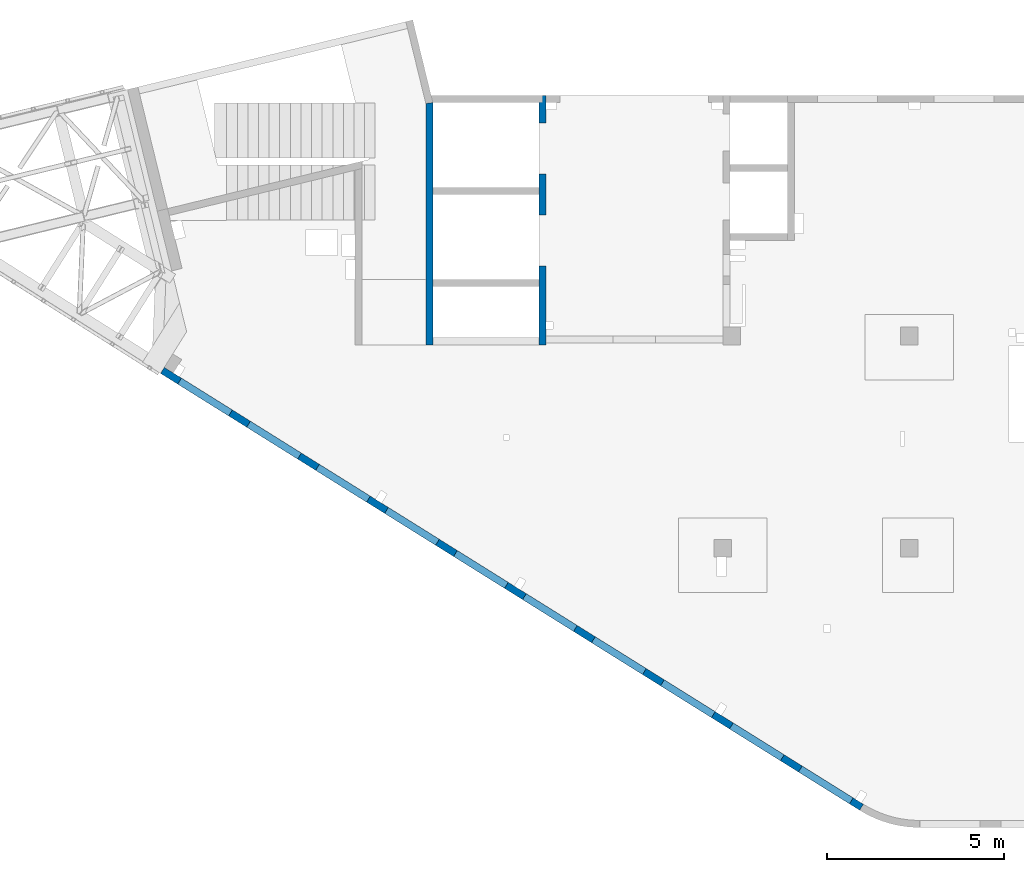
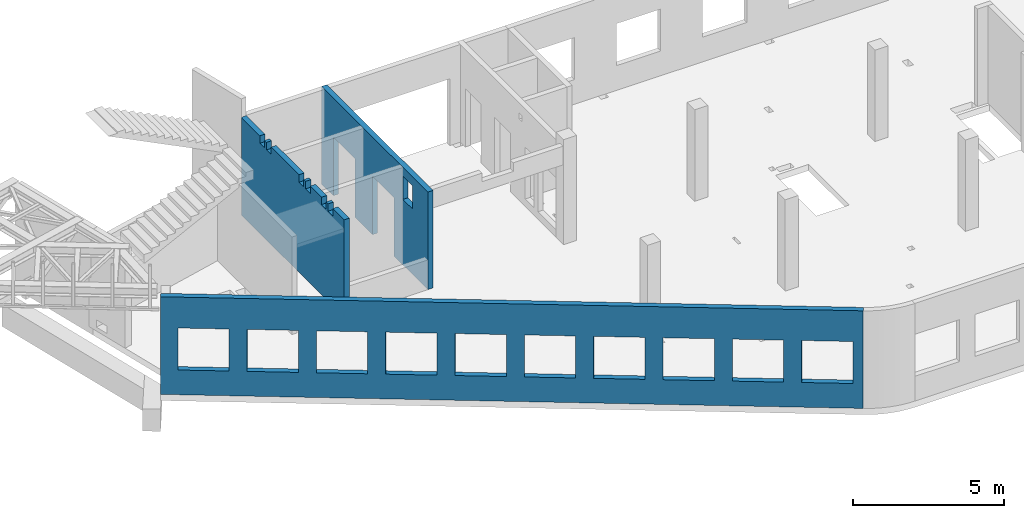
# One storey, part 64 of 67: 3 walls, 19 openings.
"""IFC4 building model written with IfcOpenShell, lengths in millimetres."""

from ifc_helpers import new_model, entity, si_unit, converted_unit, derived_unit, direction, frame, origin, place, context, subcontext, project, spatial, indexed_curve, outline, extrude, polygons, material, type_object, element, save


model = new_model("IFC4")

# Units and contexts
model_context = context("Model", 3, precision=0.01, world=origin(), true_north=direction((6.12303176911189e-17, 1.0)))
plan_context = context("Plan", 3, precision=0.01, world=origin(), true_north=direction((6.12303176911189e-17, 1.0)))
body_context = subcontext(model_context, "Body", "Model", "MODEL_VIEW")
ifc_project = project(units=[si_unit("LENGTHUNIT", "METRE", prefix="MILLI"), si_unit("AREAUNIT", "SQUARE_METRE"), si_unit("VOLUMEUNIT", "CUBIC_METRE"), converted_unit("PLANEANGLEUNIT", "DEGREE", entity("IfcRatioMeasure", 0.0174532925199433), si_unit("PLANEANGLEUNIT", "RADIAN"), dimensions=[0, 0, 0, 0, 0, 0, 0]), si_unit("MASSUNIT", "GRAM", prefix="KILO"), derived_unit("MASSDENSITYUNIT", [(si_unit("MASSUNIT", "GRAM", prefix="KILO"), 1), (si_unit("LENGTHUNIT", "METRE"), -3)]), derived_unit("MOMENTOFINERTIAUNIT", [(si_unit("LENGTHUNIT", "METRE"), 4)]), si_unit("TIMEUNIT", "SECOND"), si_unit("FREQUENCYUNIT", "HERTZ"), si_unit("THERMODYNAMICTEMPERATUREUNIT", "DEGREE_CELSIUS"), derived_unit("THERMALTRANSMITTANCEUNIT", [(si_unit("MASSUNIT", "GRAM", prefix="KILO"), 1), (si_unit("THERMODYNAMICTEMPERATUREUNIT", "KELVIN"), -1), (si_unit("TIMEUNIT", "SECOND"), -3)]), derived_unit("VOLUMETRICFLOWRATEUNIT", [(si_unit("LENGTHUNIT", "METRE"), 3), (si_unit("TIMEUNIT", "SECOND"), -1)]), derived_unit("MASSFLOWRATEUNIT", [(si_unit("MASSUNIT", "GRAM", prefix="KILO"), 1), (si_unit("TIMEUNIT", "SECOND"), -1)]), derived_unit("ROTATIONALFREQUENCYUNIT", [(si_unit("TIMEUNIT", "SECOND"), -1)]), si_unit("ELECTRICCURRENTUNIT", "AMPERE"), si_unit("ELECTRICVOLTAGEUNIT", "VOLT"), si_unit("POWERUNIT", "WATT"), si_unit("FORCEUNIT", "NEWTON", prefix="KILO"), si_unit("ILLUMINANCEUNIT", "LUX"), si_unit("LUMINOUSFLUXUNIT", "LUMEN"), si_unit("LUMINOUSINTENSITYUNIT", "CANDELA"), derived_unit("USERDEFINED", [(si_unit("MASSUNIT", "GRAM", prefix="KILO"), -1), (si_unit("LENGTHUNIT", "METRE"), -2), (si_unit("TIMEUNIT", "SECOND"), 3), (si_unit("LUMINOUSFLUXUNIT", "LUMEN"), 1)]), derived_unit("LINEARVELOCITYUNIT", [(si_unit("LENGTHUNIT", "METRE"), 1), (si_unit("TIMEUNIT", "SECOND"), -1)]), si_unit("PRESSUREUNIT", "PASCAL"), derived_unit("USERDEFINED", [(si_unit("LENGTHUNIT", "METRE"), -2), (si_unit("MASSUNIT", "GRAM", prefix="KILO"), 1), (si_unit("TIMEUNIT", "SECOND"), -2)]), derived_unit("LINEARFORCEUNIT", [(si_unit("MASSUNIT", "GRAM", prefix="KILO"), 1), (si_unit("LENGTHUNIT", "METRE"), 1), (si_unit("TIMEUNIT", "SECOND"), -2), (si_unit("LENGTHUNIT", "METRE"), -1)]), derived_unit("PLANARFORCEUNIT", [(si_unit("MASSUNIT", "GRAM", prefix="KILO"), 1), (si_unit("LENGTHUNIT", "METRE"), 1), (si_unit("TIMEUNIT", "SECOND"), -2), (si_unit("LENGTHUNIT", "METRE"), -2)])], contexts=[model_context, plan_context])

# Site, building, storey
site_placement = place(None, origin())
site = spatial("IfcSite", under=ifc_project, at=site_placement, CompositionType="ELEMENT")
building_placement = place(site_placement, origin())
building = spatial("IfcBuilding", under=site, at=building_placement, CompositionType="ELEMENT")
storey_placement = place(building_placement, frame((0.0, 0.0, 19800.0)))
storey = spatial("IfcBuildingStorey", under=building, at=storey_placement, CompositionType="ELEMENT", Elevation=19800.0)

# Wall, openings
ifc_material = material()
wall_type = type_object("IfcWallType", PredefinedType="STANDARD")
wall_1_placement = place(storey_placement, frame((19822.3508929728, 371.159406986363, -150.0), z_axis=(0.0, 0.0, 1.0), x_axis=(-0.848052743777574, 0.529911826412025, 0.0)))
wall_1 = element("IfcWall", 1, at=wall_1_placement, inside=storey, type_object=wall_type, material=ifc_material, PredefinedType="NOTDEFINED", context=body_context, shape_type="Tessellation", body=[
    polygons([(9.13669140345519e-13, -100.0, 0.0), (23011.6394501553, -99.9999999999989, 0.0), (23311.6394501553, -100.000000000001, 0.0), (23311.6394501553, -100.000000000001, 3950.0), (23011.6394501553, -99.9999999999989, 3950.0), (9.13669140345519e-13, -100.0, 3950.0), (21041.6390317217, -100.0, 2700.0), (22741.6390317217, -99.9999999999989, 2700.0), (22741.6390317217, -99.9999999999989, 1000.00000000001), (21041.6390317217, -100.0, 1000.00000000001), (18741.6390317217, -99.9999999999989, 2700.0), (20441.6390317217, -100.000000000001, 2700.0), (20441.6390317217, -100.000000000001, 1000.00000000001), (18741.6390317217, -99.9999999999989, 1000.00000000001), (16441.6390317217, -100.000000000001, 2700.0), (18141.6390317217, -100.000000000001, 2700.0), (18141.6390317217, -100.000000000001, 1000.00000000001), (16441.6390317217, -100.000000000001, 1000.00000000001), (14141.6390317217, -100.0, 2700.0), (15841.6390317217, -100.0, 2700.0), (15841.6390317217, -100.0, 1000.00000000001), (14141.6390317217, -100.0, 1000.00000000001), (11841.6390317217, -99.9999999999989, 2700.0), (13541.6390317217, -100.000000000001, 2700.0), (13541.6390317217, -100.000000000001, 1000.00000000001), (11841.6390317217, -99.9999999999989, 1000.00000000001), (9541.63903172168, -100.000000000001, 2700.0), (11241.6390317217, -100.0, 2700.0), (11241.6390317217, -100.0, 1000.00000000001), (9541.63903172168, -100.000000000001, 1000.00000000001), (7241.63903172167, -99.9999999999995, 2700.0), (8941.63903172167, -99.9999999999995, 2700.0), (8941.63903172167, -99.9999999999995, 1000.00000000001), (7241.63903172167, -99.9999999999995, 1000.00000000001), (4941.63903172166, -99.9999999999989, 2700.0), (6641.63903172166, -99.9999999999989, 2700.0), (6641.63903172166, -99.9999999999989, 1000.00000000001), (4941.63903172166, -99.9999999999989, 1000.00000000001), (2641.63903172165, -100.0, 2700.0), (4341.63903172165, -100.0, 2700.0), (4341.63903172165, -100.0, 1000.00000000001), (2641.63903172165, -100.0, 1000.00000000001), (341.639031721648, -100.000000000002, 2700.0), (2041.63903172165, -100.0, 2700.0), (2041.63903172165, -100.0, 1000.00000000001), (341.639031721648, -100.000000000002, 1000.00000000001), (22741.6390317217, 100.000000000319, 2700.0), (21041.6390317217, 100.000000000321, 2700.0), (21041.6390317217, 100.000000000321, 1000.00000000001), (22741.6390317217, 100.000000000319, 1000.00000000001), (20441.6390317217, 100.000000000319, 2700.0), (18741.6390317217, 100.000000000322, 2700.0), (18741.6390317217, 100.000000000322, 1000.00000000001), (20441.6390317217, 100.000000000319, 1000.00000000001), (18141.6390317217, 100.000000000318, 2700.0), (16441.6390317217, 100.000000000319, 2700.0), (16441.6390317217, 100.000000000319, 1000.00000000001), (18141.6390317217, 100.000000000318, 1000.00000000001), (15841.6390317217, 100.000000000321, 2700.0), (14141.6390317217, 100.000000000322, 2700.0), (14141.6390317217, 100.000000000322, 1000.00000000001), (15841.6390317217, 100.000000000321, 1000.00000000001), (13541.6390317217, 100.000000000319, 2700.0), (11841.6390317217, 100.000000000321, 2700.0), (11841.6390317217, 100.000000000321, 1000.00000000001), (13541.6390317217, 100.000000000319, 1000.00000000001), (11241.6390317217, 100.000000000321, 2700.0), (9541.63903172168, 100.000000000319, 2700.0), (9541.63903172168, 100.000000000319, 1000.00000000001), (11241.6390317217, 100.000000000321, 1000.00000000001), (8941.63903172167, 100.000000000319, 2700.0), (7241.63903172167, 100.000000000321, 2700.0), (7241.63903172167, 100.000000000321, 1000.00000000001), (8941.63903172167, 100.000000000319, 1000.00000000001), (6641.63903172167, 100.000000000322, 2700.0), (4941.63903172166, 100.000000000322, 2700.0), (4941.63903172166, 100.000000000322, 1000.00000000001), (6641.63903172166, 100.000000000322, 1000.00000000001), (4341.63903172166, 100.000000000321, 2700.0), (2641.63903172165, 100.000000000319, 2700.0), (2641.63903172165, 100.000000000319, 1000.00000000001), (4341.63903172166, 100.000000000321, 1000.00000000001), (2041.63903172165, 100.000000000321, 2700.0), (341.639031721653, 100.000000000321, 2700.0), (341.639031721653, 100.00000000032, 1000.00000000001), (2041.63903172165, 100.000000000321, 1000.00000000001), (1.18438592267012e-13, 100.000000000001, 0.0), (1.18438592267012e-13, 100.000000000001, 3950.0), (23311.6394501553, 100.000000000001, 3950.0), (23311.6394501553, 100.000000000001, 0.0)], [[[1, 2, 3, 4, 5, 6], [7, 8, 9, 10], [11, 12, 13, 14], [15, 16, 17, 18], [19, 20, 21, 22], [23, 24, 25, 26], [27, 28, 29, 30], [31, 32, 33, 34], [35, 36, 37, 38], [39, 40, 41, 42], [43, 44, 45, 46]], [[87, 88, 89, 90], [47, 48, 49, 50], [51, 52, 53, 54], [55, 56, 57, 58], [59, 60, 61, 62], [63, 64, 65, 66], [67, 68, 69, 70], [71, 72, 73, 74], [75, 76, 77, 78], [79, 80, 81, 82], [83, 84, 85, 86]], [[3, 2, 1, 87, 90]], [[6, 5, 4, 89, 88]], [[1, 6, 88, 87]], [[4, 3, 90, 89]], [[48, 47, 8, 7]], [[48, 7, 10, 49]], [[49, 10, 9, 50]], [[8, 47, 50, 9]], [[52, 51, 12, 11]], [[52, 11, 14, 53]], [[53, 14, 13, 54]], [[12, 51, 54, 13]], [[56, 55, 16, 15]], [[56, 15, 18, 57]], [[57, 18, 17, 58]], [[16, 55, 58, 17]], [[60, 59, 20, 19]], [[60, 19, 22, 61]], [[61, 22, 21, 62]], [[20, 59, 62, 21]], [[64, 63, 24, 23]], [[64, 23, 26, 65]], [[65, 26, 25, 66]], [[24, 63, 66, 25]], [[68, 67, 28, 27]], [[68, 27, 30, 69]], [[69, 30, 29, 70]], [[28, 67, 70, 29]], [[72, 71, 32, 31]], [[72, 31, 34, 73]], [[73, 34, 33, 74]], [[32, 71, 74, 33]], [[76, 75, 36, 35]], [[76, 35, 38, 77]], [[77, 38, 37, 78]], [[36, 75, 78, 37]], [[80, 79, 40, 39]], [[80, 39, 42, 81]], [[81, 42, 41, 82]], [[40, 79, 82, 41]], [[84, 83, 44, 43]], [[84, 43, 46, 85]], [[85, 46, 45, 86]], [[44, 83, 86, 45]]], closed=True),
])
opening_1_placement = place(wall_1_placement, frame((16613.7173036613, 10818.8609189489, 150.0), z_axis=(0.0, 0.0, 1.0), x_axis=(-0.848052743777574, -0.529911826412026, 0.0)))
element("IfcOpeningElement", 2, at=opening_1_placement, cuts=wall_1, PredefinedType="OPENING", context=body_context, shape_type="SweptSolid", body=[
    extrude(outline(indexed_curve([(-849.999999999993, -850.0), (849.999999999993, -850.0), (849.999999999993, 850.0), (-849.999999999993, 850.0), (-849.999999999993, -850.0)], self_intersect=False)), frame((1310.07752897418, 12056.6031038165, 1700.0), z_axis=(-0.529911826412026, -0.848052743777574, 0.0), x_axis=(0.0, 0.0, -1.0)), (0.0, 0.0, 1.0), 200.000000000959),
])
opening_2_placement = place(wall_1_placement, frame((16613.7173036613, 10818.8609189489, 150.0), z_axis=(0.0, 0.0, 1.0), x_axis=(-0.848052743777574, -0.529911826412026, 0.0)))
element("IfcOpeningElement", 3, at=opening_2_placement, cuts=wall_1, PredefinedType="OPENING", context=body_context, shape_type="SweptSolid", body=[
    extrude(outline(indexed_curve([(-849.999999999993, -850.0), (849.999999999993, -850.0), (849.999999999993, 850.0), (-849.999999999993, 850.0), (-849.999999999993, -850.0)], self_intersect=False)), frame((3260.5988396626, 10837.8059030689, 1700.0), z_axis=(-0.529911826412026, -0.848052743777574, 0.0), x_axis=(0.0, 0.0, -1.0)), (0.0, 0.0, 1.0), 200.000000000962),
])
opening_3_placement = place(wall_1_placement, frame((16613.7173036613, 10818.8609189489, 150.0), z_axis=(0.0, 0.0, 1.0), x_axis=(-0.848052743777574, -0.529911826412026, 0.0)))
element("IfcOpeningElement", 4, at=opening_3_placement, cuts=wall_1, PredefinedType="OPENING", context=body_context, shape_type="SweptSolid", body=[
    extrude(outline(indexed_curve([(-849.999999999993, -849.999999999999), (849.999999999993, -849.999999999999), (849.999999999993, 850.0), (-849.999999999993, 850.0), (-849.999999999993, -849.999999999999)], self_intersect=False)), frame((5211.12015035102, 9619.00870232123, 1700.0), z_axis=(-0.529911826412025, -0.848052743777574, 0.0), x_axis=(0.0, 0.0, -1.0)), (0.0, 0.0, 1.0), 200.000000000962),
])
opening_4_placement = place(wall_1_placement, frame((16613.7173036613, 10818.8609189489, 150.0), z_axis=(0.0, 0.0, 1.0), x_axis=(-0.848052743777574, -0.529911826412026, 0.0)))
element("IfcOpeningElement", 5, at=opening_4_placement, cuts=wall_1, PredefinedType="OPENING", context=body_context, shape_type="SweptSolid", body=[
    extrude(outline(indexed_curve([(-849.999999999993, -849.999999999999), (849.999999999993, -849.999999999999), (849.999999999993, 850.0), (-849.999999999993, 850.0), (-849.999999999993, -849.999999999999)], self_intersect=False)), frame((7161.64146103944, 8400.21150157357, 1700.0), z_axis=(-0.529911826412026, -0.848052743777574, 0.0), x_axis=(0.0, 0.0, -1.0)), (0.0, 0.0, 1.0), 200.000000000962),
])
opening_5_placement = place(wall_1_placement, frame((16613.7173036613, 10818.8609189489, 150.0), z_axis=(0.0, 0.0, 1.0), x_axis=(-0.848052743777574, -0.529911826412026, 0.0)))
element("IfcOpeningElement", 6, at=opening_5_placement, cuts=wall_1, PredefinedType="OPENING", context=body_context, shape_type="SweptSolid", body=[
    extrude(outline(indexed_curve([(-849.999999999993, -849.999999999999), (849.999999999993, -849.999999999999), (849.999999999993, 850.0), (-849.999999999993, 850.0), (-849.999999999993, -849.999999999999)], self_intersect=False)), frame((9112.16277172786, 7181.41430082591, 1700.0), z_axis=(-0.529911826412026, -0.848052743777574, 0.0), x_axis=(0.0, 0.0, -1.0)), (0.0, 0.0, 1.0), 200.000000000959),
])
opening_6_placement = place(wall_1_placement, frame((16613.7173036613, 10818.8609189489, 150.0), z_axis=(0.0, 0.0, 1.0), x_axis=(-0.848052743777574, -0.529911826412026, 0.0)))
element("IfcOpeningElement", 7, at=opening_6_placement, cuts=wall_1, PredefinedType="OPENING", context=body_context, shape_type="SweptSolid", body=[
    extrude(outline(indexed_curve([(-849.999999999993, -850.0), (849.999999999993, -850.0), (849.999999999993, 850.0), (-849.999999999993, 850.0), (-849.999999999993, -850.0)], self_intersect=False)), frame((11062.6840824163, 5962.61710007825, 1700.0), z_axis=(-0.529911826412025, -0.848052743777574, 0.0), x_axis=(0.0, 0.0, -1.0)), (0.0, 0.0, 1.0), 200.000000000964),
])
opening_7_placement = place(wall_1_placement, frame((16613.7173036613, 10818.8609189489, 150.0), z_axis=(0.0, 0.0, 1.0), x_axis=(-0.848052743777574, -0.529911826412026, 0.0)))
element("IfcOpeningElement", 8, at=opening_7_placement, cuts=wall_1, PredefinedType="OPENING", context=body_context, shape_type="SweptSolid", body=[
    extrude(outline(indexed_curve([(-849.999999999993, -850.0), (849.999999999993, -850.0), (849.999999999993, 850.0), (-849.999999999993, 850.0), (-849.999999999993, -850.0)], self_intersect=False)), frame((13013.2053931047, 4743.81989933058, 1700.0), z_axis=(-0.529911826412025, -0.848052743777574, 0.0), x_axis=(0.0, 0.0, -1.0)), (0.0, 0.0, 1.0), 200.000000000962),
])
opening_8_placement = place(wall_1_placement, frame((16613.7173036613, 10818.8609189489, 150.0), z_axis=(0.0, 0.0, 1.0), x_axis=(-0.848052743777574, -0.529911826412026, 0.0)))
element("IfcOpeningElement", 9, at=opening_8_placement, cuts=wall_1, PredefinedType="OPENING", context=body_context, shape_type="SweptSolid", body=[
    extrude(outline(indexed_curve([(-849.999999999993, -850.000000000003), (849.999999999993, -850.000000000003), (849.999999999993, 849.999999999998), (-849.999999999993, 849.999999999998), (-849.999999999993, -850.000000000003)], self_intersect=False)), frame((14963.7267037931, 3525.02269858292, 1700.0), z_axis=(-0.529911826412025, -0.848052743777574, 0.0), x_axis=(0.0, 0.0, -1.0)), (0.0, 0.0, 1.0), 200.000000000962),
])
opening_9_placement = place(wall_1_placement, frame((16613.7173036613, 10818.8609189489, 150.0), z_axis=(0.0, 0.0, 1.0), x_axis=(-0.848052743777574, -0.529911826412026, 0.0)))
element("IfcOpeningElement", 10, at=opening_9_placement, cuts=wall_1, PredefinedType="OPENING", context=body_context, shape_type="SweptSolid", body=[
    extrude(outline(indexed_curve([(-849.999999999993, -849.999999999998), (849.999999999993, -849.999999999998), (849.999999999993, 850.000000000002), (-849.999999999993, 850.000000000002), (-849.999999999993, -849.999999999998)], self_intersect=False)), frame((16914.2480144816, 2306.22549783526, 1700.0), z_axis=(-0.529911826412025, -0.848052743777574, 0.0), x_axis=(0.0, 0.0, -1.0)), (0.0, 0.0, 1.0), 200.000000000962),
])
opening_10_placement = place(wall_1_placement, frame((16613.7173036613, 10818.8609189489, 150.0), z_axis=(0.0, 0.0, 1.0), x_axis=(-0.848052743777574, -0.529911826412026, 0.0)))
element("IfcOpeningElement", 11, at=opening_10_placement, cuts=wall_1, PredefinedType="OPENING", context=body_context, shape_type="SweptSolid", body=[
    extrude(outline(indexed_curve([(-849.999999999993, -850.0), (849.999999999993, -850.0), (849.999999999993, 850.0), (-849.999999999993, 850.0), (-849.999999999993, -850.0)], self_intersect=False)), frame((18864.76932517, 1087.4282970876, 1700.0), z_axis=(-0.529911826412025, -0.848052743777574, 0.0), x_axis=(0.0, 0.0, -1.0)), (0.0, 0.0, 1.0), 200.000000000962),
])

wall_2_placement = place(storey_placement, frame((10800.0002685547, 20499.9998657227, -150.0), z_axis=(0.0, 0.0, 1.0), x_axis=(0.0, -1.0, 0.0)))
wall_2 = element("IfcWall", 12, at=wall_2_placement, inside=storey, type_object=wall_type, material=ifc_material, PredefinedType="NOTDEFINED", context=body_context, shape_type="Tessellation", body=[
    polygons([(5400.00000000001, -100.0, 3600.0), (6050.00000000001, -100.000000000001, 3600.0), (6050.00000000001, -100.000000000001, 2650.00000000001), (5400.00000000001, -100.0, 2650.00000000001), (7050.00063936681, -100.000000000002, 3950.0), (6850.0006393668, -100.000000000002, 3950.0), (5400.00000000001, -100.0, 3950.0), (5200.00000000001, -100.000000000001, 3950.0), (2800.00000000001, -100.000000000001, 3950.0), (2600.00000000001, -100.000000000001, 3950.0), (200.000000000002, -100.000000000001, 3950.0), (4.33146851719357e-12, -100.000000000001, 3950.0), (4.33146851719357e-12, -100.000000000001, 49.9999999999973), (4.33146851719357e-12, -100.000000000001, 0.0), (200.000000000002, -100.000000000001, 0.0), (780.000000000005, -100.000000000002, 0.0), (780.000000000005, -100.000000000002, 2369.99999999805), (2220.0, -100.000000000002, 2369.99999999804), (2220.0, -100.000000000002, 0.0), (3380.0, -100.000000000002, 0.0), (3380.0, -100.000000000002, 2369.99999999805), (4820.0, -100.000000000001, 2369.99999999805), (4820.0, -100.000000000001, 0.0), (6850.00063936681, -100.000000000002, 0.0), (7050.00063936681, -100.000000000002, 0.0), (7050.00063936681, -100.000000000002, 1200.0), (6050.0, 100.000000000321, 3600.0), (5400.0, 100.00000000032, 3600.0), (5400.00000000001, 100.00000000032, 2650.00000000001), (6050.0, 100.000000000321, 2650.00000000001), (0.0, 99.9999999999987, 3950.0), (199.999999999998, 99.999999999999, 3950.0), (400.0, 99.9999999999994, 3950.0), (6400.00063936679, 99.9999999999994, 3950.0), (6600.00063936679, 99.9999999999998, 3950.0), (6800.00063936679, 99.999999999998, 3950.0), (7000.00063936679, 99.9999999999984, 3950.0), (7050.00063936681, 99.9999999999984, 3950.0), (7050.0006393668, 99.9999999999984, 0.0), (6600.00063936679, 99.9999999999998, 0.0), (6400.00063936679, 99.9999999999994, 0.0), (4819.99999999999, 99.9999999999987, 0.0), (4820.0, 99.9999999999987, 2369.99999999805), (3380.0, 99.9999999999983, 2369.99999999804), (3380.0, 99.9999999999983, 0.0), (2220.0, 99.9999999999984, 0.0), (2220.0, 99.9999999999984, 2369.99999999804), (780.0, 100.0, 2369.99999999805), (780.0, 99.9999999999979, 0.0), (399.999999999965, 99.9999999999994, 0.0), (199.999999999998, 99.999999999999, 0.0), (0.0, 99.9999999999987, 0.0), (0.0, -2.40817119847655e-12, 0.0)], [[[5, 6, 7, 8, 9, 10, 11, 12, 13, 14, 15, 16, 17, 18, 19, 20, 21, 22, 23, 24, 25, 26], [1, 2, 3, 4]], [[31, 32, 33, 34, 35, 36, 37, 38, 39, 40, 41, 42, 43, 44, 45, 46, 47, 48, 49, 50, 51, 52], [27, 28, 29, 30]], [[16, 15, 14, 53, 52, 51, 50, 49]], [[12, 11, 10, 9, 8, 7, 6, 5, 38, 37, 36, 35, 34, 33, 32, 31]], [[43, 22, 21, 44]], [[44, 21, 20, 45]], [[22, 43, 42, 23]], [[17, 48, 47, 18]], [[18, 47, 46, 19]], [[48, 17, 16, 49]], [[28, 27, 2, 1]], [[28, 1, 4, 29]], [[29, 4, 3, 30]], [[2, 27, 30, 3]], [[5, 26, 25, 39, 38]], [[52, 53, 14, 13, 12, 31]], [[19, 46, 45, 20]], [[39, 25, 24, 23, 42, 41, 40]]], closed=True),
])
opening_11_placement = place(wall_2_placement, frame((20499.9998657227, -10800.0002685547, 150.0), z_axis=(0.0, 0.0, 1.0), x_axis=(0.0, 1.0, 0.0)))
element("IfcOpeningElement", 13, at=opening_11_placement, cuts=wall_2, PredefinedType="OPENING", context=body_context, shape_type="SweptSolid", body=[
    extrude(outline(indexed_curve([(-719.999999999999, -1184.99999999902), (719.999999999999, -1184.99999999902), (719.999999999999, 1184.99999999902), (-719.999999999999, 1184.99999999902), (-719.999999999999, -1184.99999999902)], self_intersect=False)), frame((10600.0002685528, 18999.9998657227, 1035.0), z_axis=(1.0, 0.0, 0.0), x_axis=(0.0, -1.0, 0.0)), (0.0, 0.0, 1.0), 400.000000001943),
])
opening_12_placement = place(wall_2_placement, frame((20499.9998657227, -10800.0002685547, 150.0), z_axis=(0.0, 0.0, 1.0), x_axis=(0.0, 1.0, 0.0)))
element("IfcOpeningElement", 14, at=opening_12_placement, cuts=wall_2, PredefinedType="OPENING", context=body_context, shape_type="SweptSolid", body=[
    extrude(outline(indexed_curve([(-1184.99999999902, -719.999999999999), (1184.99999999902, -719.999999999999), (1184.99999999902, 720.000000000001), (-1184.99999999902, 720.000000000001), (-1184.99999999902, -719.999999999999)], self_intersect=False)), frame((10600.0002685547, 16399.9998657227, 1035.0), z_axis=(1.0, 0.0, 0.0), x_axis=(0.0, 0.0, -1.0)), (0.0, 0.0, 1.0), 400.000000001943),
])
opening_13_placement = place(wall_2_placement, frame((20499.9998657227, -10800.0002685547, 150.0), z_axis=(0.0, 0.0, 1.0), x_axis=(0.0, 1.0, 0.0)))
element("IfcOpeningElement", 15, at=opening_13_placement, cuts=wall_2, PredefinedType="OPENING", context=body_context, shape_type="SweptSolid", body=[
    extrude(outline(indexed_curve([(-474.999999999996, -325.0), (474.999999999992, -325.0), (474.999999999992, 325.0), (-474.999999999996, 325.0), (-474.999999999996, -325.0)], self_intersect=False)), frame((10700.0002685547, 14774.9998657227, 2975.0), z_axis=(1.0, 0.0, 0.0), x_axis=(0.0, 0.0, -1.0)), (0.0, 0.0, 1.0), 200.000000000962),
])

wall_3_placement = place(storey_placement, frame((7600.0002685547, 20297.5240905813, -150.0), z_axis=(0.0, 0.0, 1.0), x_axis=(0.0, -1.0, 0.0)))
wall_3 = element("IfcWall", 16, at=wall_3_placement, inside=storey, type_object=wall_type, material=ifc_material, PredefinedType="NOTDEFINED", context=body_context, shape_type="Tessellation", body=[
    polygons([(24.0243306802226, -100.0, 0.0), (6847.52486422541, -99.9999999999992, 0.0), (6847.52486422541, -99.9999999999992, 3950.0), (6092.52422485862, -100.000000000001, 3950.0), (6092.52422485862, -100.000000000001, 3650.00000000001), (5782.52422485862, -100.0, 3650.00000000001), (5782.52422485862, -100.0, 3950.0), (5652.52422485862, -100.0, 3950.0), (5652.52422485862, -100.0, 3650.00000000001), (5342.52422485862, -100.000000000001, 3650.00000000001), (5342.52422485862, -100.000000000001, 3950.0), (4596.52422485859, -100.000000000001, 3950.0), (4596.52422485859, -100.000000000001, 3650.00000000001), (4286.52422485859, -100.000000000001, 3650.00000000001), (4286.52422485859, -100.000000000001, 3950.0), (4156.52422485859, -100.000000000002, 3950.0), (4156.52422485859, -100.000000000002, 3650.00000000001), (3846.52422485859, -100.0, 3650.00000000001), (3846.52422485859, -100.0, 3950.0), (1996.52422485859, -99.9999999999989, 3950.0), (1996.52422485859, -99.9999999999989, 3650.00000000001), (1686.52422485859, -99.9999999999994, 3650.00000000001), (1686.52422485859, -99.9999999999994, 3950.0), (1556.52422485858, -99.9999999999996, 3950.0), (1556.52422485858, -99.9999999999996, 3650.00000000001), (1246.52422485858, -100.0, 3650.00000000001), (1246.52422485858, -100.0, 3950.0), (24.0243306802226, -100.0, 3950.0), (6847.52486422541, 99.9999999999997, 0.0), (6647.52486422541, 99.9999999999993, 0.0), (0.0, 99.9999999999999, 0.0), (0.0, 99.9999999999999, 3950.0), (1246.52422485858, 99.9999999999998, 3950.0), (1246.52422485859, 100.00000000032, 3650.00000000001), (1556.52422485858, 100.00000000032, 3650.00000000001), (1556.52422485858, 99.9999999999993, 3950.0), (1686.52422485859, 99.9999999999995, 3950.0), (1686.52422485859, 100.00000000032, 3650.00000000001), (1996.52422485859, 100.000000000321, 3650.00000000001), (1996.52422485859, 100.0, 3950.0), (2397.52422485862, 99.9999999999996, 3950.0), (2597.52422485862, 100.0, 3950.0), (3846.52422485859, 100.0, 3950.0), (3846.52422485859, 100.000000000319, 3650.00000000001), (4156.52422485859, 100.00000000032, 3650.00000000001), (4156.52422485859, 99.9999999999994, 3950.0), (4286.52422485859, 99.9999999999996, 3950.0), (4286.52422485859, 100.00000000032, 3650.00000000001), (4596.52422485859, 100.000000000321, 3650.00000000001), (4596.52422485859, 100.0, 3950.0), (4997.52422485862, 99.9999999999998, 3950.0), (5197.52422485862, 100.0, 3950.0), (5342.52422485862, 99.9999999999982, 3950.0), (5342.52422485862, 100.000000000319, 3650.00000000001), (5652.52422485862, 100.000000000319, 3650.00000000001), (5652.52422485862, 99.9999999999987, 3950.0), (5782.52422485862, 99.999999999999, 3950.0), (5782.52422485862, 100.000000000319, 3650.00000000001), (6092.52422485862, 100.00000000032, 3650.00000000001), (6092.52422485862, 99.9999999999995, 3950.0), (6647.5248642254, 99.9999999999993, 3950.0), (6847.52486422541, 99.9999999999997, 3950.0), (6847.52486422541, 99.9999999999997, 1200.0)], [[[1, 2, 3, 4, 5, 6, 7, 8, 9, 10, 11, 12, 13, 14, 15, 16, 17, 18, 19, 20, 21, 22, 23, 24, 25, 26, 27, 28]], [[29, 30, 31, 32, 33, 34, 35, 36, 37, 38, 39, 40, 41, 42, 43, 44, 45, 46, 47, 48, 49, 50, 51, 52, 53, 54, 55, 56, 57, 58, 59, 60, 61, 62, 63]], [[2, 1, 31, 30, 29]], [[4, 3, 62, 61, 60]], [[10, 54, 53, 11]], [[54, 10, 9, 55]], [[55, 9, 8, 56]], [[6, 58, 57, 7]], [[58, 6, 5, 59]], [[59, 5, 4, 60]], [[3, 2, 29, 63, 62]], [[14, 48, 47, 15]], [[48, 14, 13, 49]], [[49, 13, 12, 50]], [[18, 44, 43, 19]], [[44, 18, 17, 45]], [[45, 17, 16, 46]], [[22, 38, 37, 23]], [[38, 22, 21, 39]], [[39, 21, 20, 40]], [[26, 34, 33, 27]], [[34, 26, 25, 35]], [[35, 25, 24, 36]], [[1, 28, 32, 31]], [[11, 53, 52, 51, 50, 12]], [[15, 47, 46, 16]], [[19, 43, 42, 41, 40, 20]], [[23, 37, 36, 24]], [[56, 8, 7, 57]], [[32, 28, 27, 33]]], closed=True),
])
opening_14_placement = place(wall_3_placement, frame((20297.5240905813, -7600.0002685547, 150.0), z_axis=(0.0, 0.0, 1.0), x_axis=(0.0, 1.0, 0.0)))
element("IfcOpeningElement", 17, at=opening_14_placement, cuts=wall_3, PredefinedType="OPENING", context=body_context, shape_type="SweptSolid", body=[
    extrude(outline(indexed_curve([(-154.999999999995, -154.999999999999), (154.999999999991, -154.999999999999), (154.999999999991, 154.999999999999), (-154.999999999995, 154.999999999999), (-154.999999999995, -154.999999999999)], self_intersect=False)), frame((7500.00026855469, 14799.9998657227, 3655.0), z_axis=(1.0, 0.0, 0.0), x_axis=(0.0, 0.0, -1.0)), (0.0, 0.0, 1.0), 200.000000000962),
])
opening_15_placement = place(wall_3_placement, frame((20297.5240905813, -7600.0002685547, 150.0), z_axis=(0.0, 0.0, 1.0), x_axis=(0.0, 1.0, 0.0)))
element("IfcOpeningElement", 18, at=opening_15_placement, cuts=wall_3, PredefinedType="OPENING", context=body_context, shape_type="SweptSolid", body=[
    extrude(outline(indexed_curve([(-154.999999999995, -154.999999999999), (154.999999999991, -154.999999999999), (154.999999999991, 154.999999999999), (-154.999999999995, 154.999999999999), (-154.999999999995, -154.999999999999)], self_intersect=False)), frame((7500.00026855469, 14359.9998657227, 3655.0), z_axis=(1.0, 0.0, 0.0), x_axis=(0.0, 0.0, -1.0)), (0.0, 0.0, 1.0), 200.000000000962),
])
opening_16_placement = place(wall_3_placement, frame((20297.5240905813, -7600.0002685547, 150.0), z_axis=(0.0, 0.0, 1.0), x_axis=(0.0, 1.0, 0.0)))
element("IfcOpeningElement", 19, at=opening_16_placement, cuts=wall_3, PredefinedType="OPENING", context=body_context, shape_type="SweptSolid", body=[
    extrude(outline(indexed_curve([(-154.999999999995, -154.999999999999), (154.999999999991, -154.999999999999), (154.999999999991, 154.999999999999), (-154.999999999995, 154.999999999999), (-154.999999999995, -154.999999999999)], self_intersect=False)), frame((7500.00026855469, 15855.9998657227, 3655.0), z_axis=(1.0, 0.0, 0.0), x_axis=(0.0, 0.0, -1.0)), (0.0, 0.0, 1.0), 200.000000000962),
])
opening_17_placement = place(wall_3_placement, frame((20297.5240905813, -7600.0002685547, 150.0), z_axis=(0.0, 0.0, 1.0), x_axis=(0.0, 1.0, 0.0)))
element("IfcOpeningElement", 20, at=opening_17_placement, cuts=wall_3, PredefinedType="OPENING", context=body_context, shape_type="SweptSolid", body=[
    extrude(outline(indexed_curve([(-154.999999999995, -154.999999999999), (154.999999999991, -154.999999999999), (154.999999999991, 154.999999999999), (-154.999999999995, 154.999999999999), (-154.999999999995, -154.999999999999)], self_intersect=False)), frame((7500.00026855469, 16295.9998657227, 3655.0), z_axis=(1.0, 0.0, 0.0), x_axis=(0.0, 0.0, -1.0)), (0.0, 0.0, 1.0), 200.000000000962),
])
opening_18_placement = place(wall_3_placement, frame((20297.5240905813, -7600.0002685547, 150.0), z_axis=(0.0, 0.0, 1.0), x_axis=(0.0, 1.0, 0.0)))
element("IfcOpeningElement", 21, at=opening_18_placement, cuts=wall_3, PredefinedType="OPENING", context=body_context, shape_type="SweptSolid", body=[
    extrude(outline(indexed_curve([(-154.999999999995, -154.999999999999), (154.999999999991, -154.999999999999), (154.999999999991, 154.999999999999), (-154.999999999995, 154.999999999999), (-154.999999999995, -154.999999999999)], self_intersect=False)), frame((7500.0002685547, 18455.9998657227, 3655.0), z_axis=(1.0, 0.0, 0.0), x_axis=(0.0, 0.0, -1.0)), (0.0, 0.0, 1.0), 200.000000000962),
])
opening_19_placement = place(wall_3_placement, frame((20297.5240905813, -7600.0002685547, 150.0), z_axis=(0.0, 0.0, 1.0), x_axis=(0.0, 1.0, 0.0)))
element("IfcOpeningElement", 22, at=opening_19_placement, cuts=wall_3, PredefinedType="OPENING", context=body_context, shape_type="SweptSolid", body=[
    extrude(outline(indexed_curve([(-154.999999999995, -154.999999999999), (154.999999999991, -154.999999999999), (154.999999999991, 154.999999999999), (-154.999999999995, 154.999999999999), (-154.999999999995, -154.999999999999)], self_intersect=False)), frame((7500.0002685547, 18895.9998657227, 3655.0), z_axis=(1.0, 0.0, 0.0), x_axis=(0.0, 0.0, -1.0)), (0.0, 0.0, 1.0), 200.000000000962),
])

save(model, "model.ifc")
